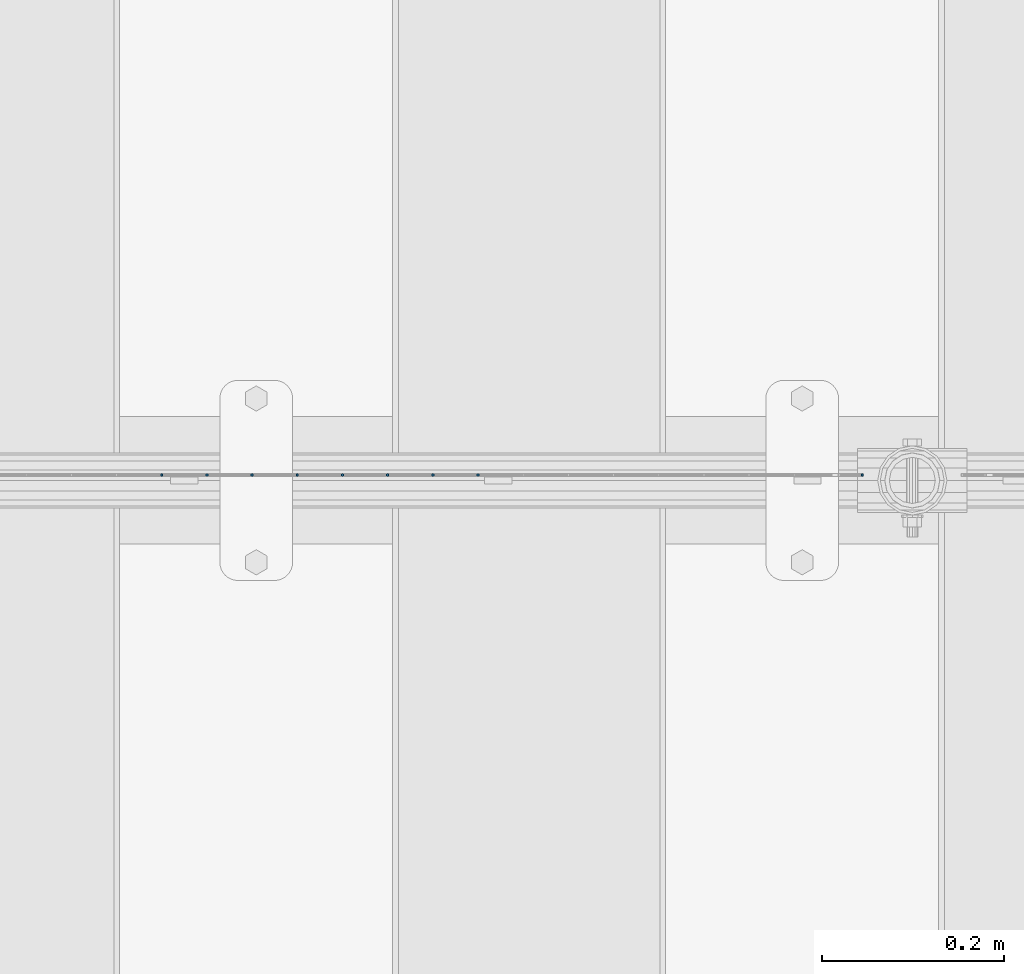
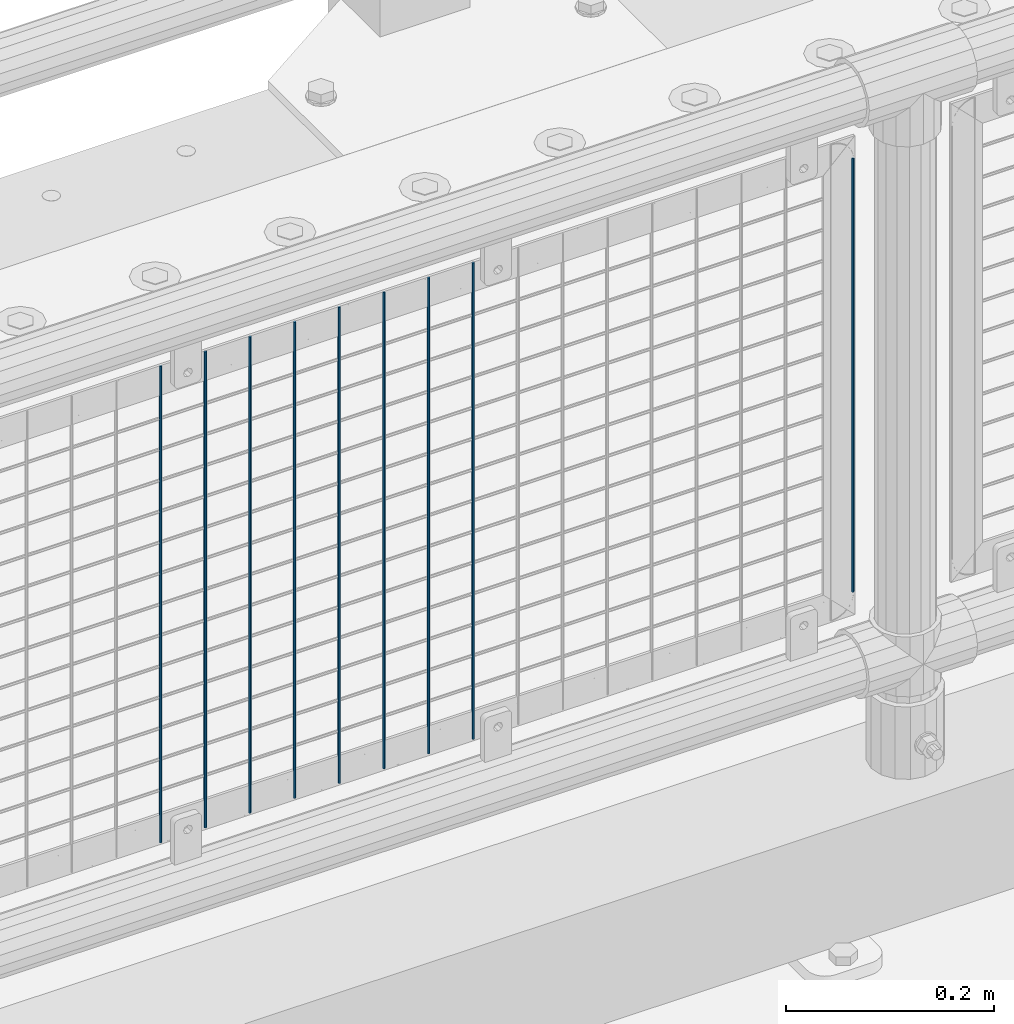
# One storey, part 60 of 208: 9 columns.
"""IFC2X3 building model written with IfcOpenShell, lengths in millimetres."""

from ifc_helpers import new_model, si_unit, frame, origin_with_axes, place, context, subcontext, project, spatial, faceted_brep, material, type_object, element, save


model = new_model("IFC2X3")

# Units and contexts
model_context = context("Model", 3, precision=1e-05, world=origin_with_axes())
body_context = subcontext(model_context, "Body", "Model", "MODEL_VIEW")
ifc_project = project(units=[si_unit("LENGTHUNIT", "METRE", prefix="MILLI"), si_unit("AREAUNIT", "SQUARE_METRE"), si_unit("VOLUMEUNIT", "CUBIC_METRE"), si_unit("MASSUNIT", "GRAM", prefix="KILO"), si_unit("TIMEUNIT", "SECOND"), si_unit("PLANEANGLEUNIT", "RADIAN"), si_unit("SOLIDANGLEUNIT", "STERADIAN"), si_unit("THERMODYNAMICTEMPERATUREUNIT", "DEGREE_CELSIUS"), si_unit("LUMINOUSINTENSITYUNIT", "LUMEN")], contexts=[model_context])

# Site, building, storey
site_placement = place(None, origin_with_axes())
site = spatial("IfcSite", under=ifc_project, at=site_placement, CompositionType="ELEMENT")
building_placement = place(site_placement, origin_with_axes())
building = spatial("IfcBuilding", under=site, at=building_placement, Name="Standard", CompositionType="ELEMENT")
storey_placement = place(building_placement, origin_with_axes())
storey = spatial("IfcBuildingStorey", under=building, at=storey_placement, Name="Undefined", CompositionType="ELEMENT", Elevation=0.0)

# Columns
ifc_material = material(Name="Misc_Undefined")
column_type = type_object("IfcColumnType", Name="D3", PredefinedType="NOTDEFINED")
for number, where, z_axis, x_axis in (
    (1, (-39106.245, 4670.5, 353.02), (-1.0, 0.0, 0.0), (0.0, 0.0, 1.0)),
    (2, (-39155.9, 4670.5, 353.02), (-1.0, 0.0, 0.0), (0.0, 0.0, 1.0)),
    (3, (-39205.555, 4670.5, 353.02), (-1.0, 0.0, 0.0), (0.0, 0.0, 1.0)),
    (4, (-39255.21, 4670.5, 353.02), (-1.0, 0.0, 0.0), (0.0, 0.0, 1.0)),
    (5, (-39304.865, 4670.5, 353.02), (-1.0, 0.0, 0.0), (0.0, 0.0, 1.0)),
    (6, (-39354.52, 4670.5, 353.02), (-1.0, 0.0, 0.0), (0.0, 0.0, 1.0)),
    (7, (-39404.175, 4670.5, 353.02), (-1.0, 0.0, 0.0), (0.0, 0.0, 1.0)),
    (8, (-39453.83, 4670.5, 353.02), (-1.0, 0.0, 0.0), (0.0, 0.0, 1.0)),
):
    element("IfcColumn", number, at=place(storey_placement, frame(where, z_axis=z_axis, x_axis=x_axis)), inside=storey, type_object=column_type, material=ifc_material, ObjectType="D3", context=body_context, shape_type="Brep", body=[
        faceted_brep([(0.0, -1.49999999999909, 3.63797880709171e-12), (-7.27595761418343e-12, -0.749999999999091, -1.29903810567669), (560.0, -0.75, -1.29903810567703), (560.0, -1.5, 0.0), (-3.63797880709171e-12, 0.750000000000909, -1.29903810567669), (560.0, 0.75, -1.29903810567703), (0.0, 1.50000000000182, 3.63797880709171e-12), (560.0, 1.5, 0.0), (-3.63797880709171e-12, 0.750000000000909, 1.29903810567669), (560.0, 0.75, 1.29903810567703), (-7.27595761418343e-12, -0.749999999999091, 1.29903810567669), (560.0, -0.75, 1.29903810567703)], [[[0, 1, 2, 3]], [[1, 4, 5, 2]], [[4, 6, 7, 5]], [[6, 8, 9, 7]], [[8, 10, 11, 9]], [[10, 0, 3, 11]], [[5, 7, 9, 11, 3, 2]], [[10, 8, 6, 4, 1, 0]]]),
    ])
column_placement = place(storey_placement, frame((-38684.0, 4670.5, 378.02), z_axis=(-1.0, 0.0, 0.0), x_axis=(0.0, 0.0, 1.0)))
element("IfcColumn", 9, at=column_placement, inside=storey, type_object=column_type, material=ifc_material, ObjectType="D3", context=body_context, shape_type="Brep", body=[
    faceted_brep([(0.0, -1.49999999999909, 3.63797880709171e-12), (-7.27595761418343e-12, -0.749999999999091, -1.29903810567669), (510.0, -0.75, -1.29903810567703), (510.0, -1.5, 0.0), (-3.63797880709171e-12, 0.750000000000909, -1.29903810567669), (510.0, 0.75, -1.29903810567703), (0.0, 1.50000000000182, 3.63797880709171e-12), (510.0, 1.5, 0.0), (-3.63797880709171e-12, 0.750000000000909, 1.29903810567669), (510.0, 0.75, 1.29903810567703), (-7.27595761418343e-12, -0.749999999999091, 1.29903810567669), (510.0, -0.75, 1.29903810567703)], [[[0, 1, 2, 3]], [[1, 4, 5, 2]], [[4, 6, 7, 5]], [[6, 8, 9, 7]], [[8, 10, 11, 9]], [[10, 0, 3, 11]], [[5, 7, 9, 11, 3, 2]], [[10, 8, 6, 4, 1, 0]]]),
])

save(model, "model.ifc")
